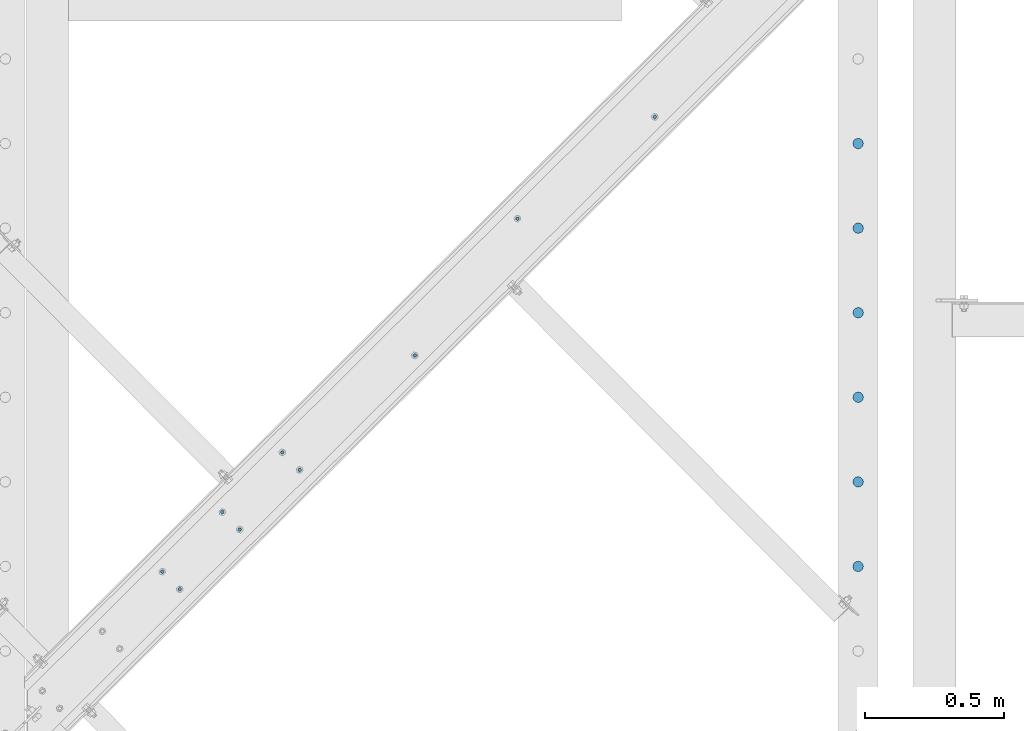
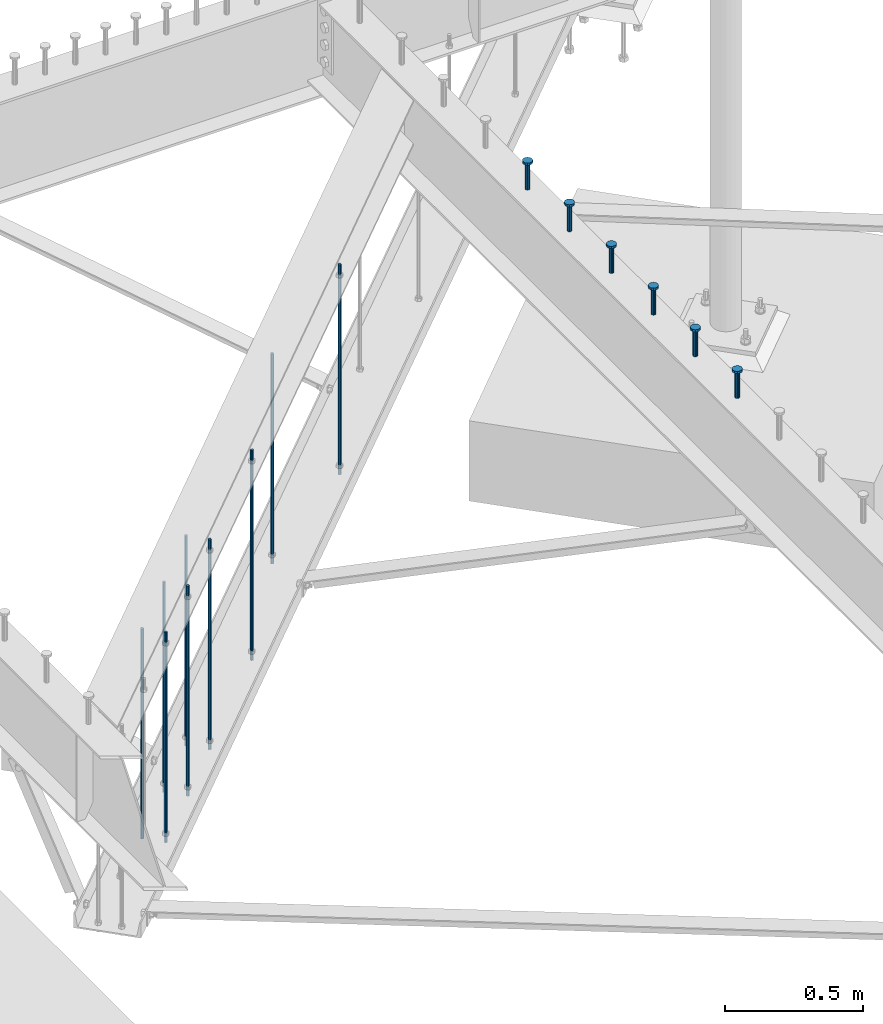
# One storey, part 204 of 975: 15 columns.
"""IFC2X3 building model written with IfcOpenShell, lengths in millimetres."""

from ifc_helpers import new_model, si_unit, frame, origin_with_axes, place, context, subcontext, project, spatial, faceted_brep, material, type_object, element, save


model = new_model("IFC2X3")

# Units and contexts
model_context = context("Model", 3, precision=1e-05, world=origin_with_axes())
body_context = subcontext(model_context, "Body", "Model", "MODEL_VIEW")
ifc_project = project(units=[si_unit("LENGTHUNIT", "METRE", prefix="MILLI"), si_unit("AREAUNIT", "SQUARE_METRE"), si_unit("VOLUMEUNIT", "CUBIC_METRE"), si_unit("MASSUNIT", "GRAM", prefix="KILO"), si_unit("TIMEUNIT", "SECOND"), si_unit("PLANEANGLEUNIT", "RADIAN"), si_unit("SOLIDANGLEUNIT", "STERADIAN"), si_unit("THERMODYNAMICTEMPERATUREUNIT", "DEGREE_CELSIUS"), si_unit("LUMINOUSINTENSITYUNIT", "LUMEN")], contexts=[model_context])

# Site, building, storey
site_placement = place(None, origin_with_axes())
site = spatial("IfcSite", under=ifc_project, at=site_placement, CompositionType="ELEMENT")
building_placement = place(site_placement, origin_with_axes())
building = spatial("IfcBuilding", under=site, at=building_placement, Name="Undefined", CompositionType="ELEMENT")
storey_placement = place(building_placement, origin_with_axes())
storey = spatial("IfcBuildingStorey", under=building, at=storey_placement, Name="Undefined", CompositionType="ELEMENT", Elevation=0.0)

# Columns
ifc_material_1 = material(Name="STEEL/A36")
column_type_1 = type_object("IfcColumnType", PredefinedType="NOTDEFINED")
for number, where, z_axis, x_axis, name in (
    (1, (25047.2443568091, 11120.5428003824, 2870.2), (-0.705007718837806, 0.709199630836842, 0.0), (0.0, 0.0, 1.0), "ALL-THREAD ROD"),
    (2, (25416.8597039642, 11613.4022454247, 2870.2), (-0.705007718837806, 0.709199630836842, 0.0), (0.0, 0.0, 1.0), "ALL-THREAD ROD"),
    (3, (24632.1764227928, 10708.0351225821, 2870.2), (-0.705007718837806, 0.709199630836842, 0.0), (0.0, 0.0, 1.0), "ALL-THREAD ROD"),
    (4, (24416.0123929391, 10493.1487521493, 2870.2), (-0.705007718837806, 0.709199630836842, 0.0), (0.0, 0.0, 1.0), "ALL-THREAD ROD"),
    (5, (24353.3372015628, 10556.1965941899, 2870.2), (-0.705007718837806, 0.709199630836842, 0.0), (0.0, 0.0, 1.0), "ALL-THREAD ROD"),
    (6, (24137.1731717091, 10341.3102237571, 2870.2), (-0.705007718837806, 0.709199630836842, 0.0), (0.0, 0.0, 1.0), "ALL-THREAD ROD"),
    (7, (24199.8483630854, 10278.2623817164, 2870.2), (-0.705007718837806, 0.709199630836842, 0.0), (0.0, 0.0, 1.0), "ALL-THREAD ROD"),
    (8, (25911.9004762635, 11980.0882821533, 2870.2), (-0.705007718837806, 0.709199630836842, 0.0), (0.0, 0.0, 1.0), "ALL-THREAD ROD"),
    (9, (24569.5012314165, 10771.0829646228, 2870.2), (-0.705007718837806, 0.709199630836842, 0.0), (0.0, 0.0, 1.0), "ALL-THREAD ROD"),
):
    element("IfcColumn", number, at=place(storey_placement, frame(where, z_axis=z_axis, x_axis=x_axis)), inside=storey, type_object=column_type_1, material=ifc_material_1, Name=name, context=body_context, shape_type="Brep", body=[
        faceted_brep([(0.0, -6.34999999998763, -3.63797880709171e-12), (0.0, -4.49012806052269, -4.49012806054634), (931.8625, -4.49012806052269, -4.49012806054634), (931.8625, -6.34999999998763, -3.63797880709171e-12), (0.0, 7.27595761418343e-12, -6.35000000000764), (931.8625, 7.27595761418343e-12, -6.35000000000764), (0.0, 4.49012806053724, -4.49012806053906), (931.8625, 4.49012806053724, -4.49012806053906), (0.0, 6.34999999999491, 5.45696821063757e-12), (931.8625, 6.34999999999491, 5.45696821063757e-12), (0.0, 4.49012806052633, 4.49012806054634), (931.8625, 4.49012806052633, 4.49012806054634), (0.0, 0.0, 6.35000000000764), (931.8625, 0.0, 6.35000000000764), (0.0, -4.49012806053361, 4.49012806053543), (931.8625, -4.49012806053361, 4.49012806053543)], [[[0, 1, 2, 3]], [[1, 4, 5, 2]], [[4, 6, 7, 5]], [[6, 8, 9, 7]], [[8, 10, 11, 9]], [[10, 12, 13, 11]], [[12, 14, 15, 13]], [[14, 0, 3, 15]], [[5, 7, 9, 11, 13, 15, 3, 2]], [[14, 12, 10, 8, 6, 4, 1, 0]]]),
    ])
ifc_material_2 = material(Name="STEEL/A108")
column_type_2 = type_object("IfcColumnType", Name="STUD_3/4-DIA", PredefinedType="NOTDEFINED")
column_1_placement = place(storey_placement, frame((26644.6662714101, 11884.025, 3937.0), z_axis=(0.0, 1.0, 0.0), x_axis=(0.0, 0.0, 1.0)))
element("IfcColumn", 10, at=column_1_placement, inside=storey, type_object=column_type_2, material=ifc_material_2, ObjectType="STUD_3/4-DIA", context=body_context, shape_type="Brep", body=[
    faceted_brep([(0.0, -9.52000045776367, 0.0), (0.0, -8.25, -4.76000022888184), (115.57, -8.25, -4.76000022888184), (115.57, -9.52000045776367, 0.0), (0.0, -4.76000022888184, -8.25), (115.57, -4.76000022888184, -8.25), (0.0, 0.0, -9.52000045776367), (115.57, 0.0, -9.52000045776367), (0.0, 4.76000022888184, -8.25), (115.57, 4.76000022888184, -8.25), (0.0, 8.25, -4.76000022888184), (115.57, 8.25, -4.76000022888184), (0.0, 9.52000045776367, 0.0), (115.57, 9.52000045776367, 0.0), (0.0, 8.25, 4.76000022888184), (115.57, 8.25, 4.76000022888184), (0.0, 4.76000022888184, 8.25), (115.57, 4.76000022888184, 8.25), (0.0, 0.0, 9.52000045776367), (115.57, 0.0, 9.52000045776367), (0.0, -4.76000022888184, 8.25), (115.57, -4.76000022888184, 8.25), (0.0, -8.25, 4.76000022888184), (115.57, -8.25, 4.76000022888184), (116.84, -16.5, -9.52000045776367), (116.84, -19.0499992370605, 0.0), (116.84, -9.52000045776367, -16.5), (116.84, 0.0, -19.0499992370605), (116.84, 9.52000045776367, -16.5), (116.84, 16.5, -9.52000045776367), (116.84, 19.0499992370605, 0.0), (116.84, 16.5, 9.52000045776367), (116.84, 9.52000045776367, 16.5), (116.84, 0.0, 19.0499992370605), (116.84, -9.52000045776367, 16.5), (116.84, -16.5, 9.52000045776367), (127.0, -16.5, -9.52000045776367), (127.0, -19.0499992370605, 0.0), (127.0, -9.52000045776367, -16.5), (127.0, 0.0, -19.0499992370605), (127.0, 9.52000045776367, -16.5), (127.0, 16.5, -9.52000045776367), (127.0, 19.0499992370605, 0.0), (127.0, 16.5, 9.52000045776367), (127.0, 9.52000045776367, 16.5), (127.0, 0.0, 19.0499992370605), (127.0, -9.52000045776367, 16.5), (127.0, -16.5, 9.52000045776367)], [[[0, 1, 2, 3]], [[1, 4, 5, 2]], [[4, 6, 7, 5]], [[6, 8, 9, 7]], [[8, 10, 11, 9]], [[10, 12, 13, 11]], [[12, 14, 15, 13]], [[14, 16, 17, 15]], [[16, 18, 19, 17]], [[18, 20, 21, 19]], [[20, 22, 23, 21]], [[22, 0, 3, 23]], [[22, 20, 18, 16, 14, 12, 10, 8, 6, 4, 1, 0]], [[3, 2, 24, 25]], [[2, 5, 26, 24]], [[5, 7, 27, 26]], [[7, 9, 28, 27]], [[9, 11, 29, 28]], [[11, 13, 30, 29]], [[13, 15, 31, 30]], [[15, 17, 32, 31]], [[17, 19, 33, 32]], [[19, 21, 34, 33]], [[21, 23, 35, 34]], [[23, 3, 25, 35]], [[25, 24, 36, 37]], [[24, 26, 38, 36]], [[26, 27, 39, 38]], [[27, 28, 40, 39]], [[28, 29, 41, 40]], [[29, 30, 42, 41]], [[30, 31, 43, 42]], [[31, 32, 44, 43]], [[32, 33, 45, 44]], [[33, 34, 46, 45]], [[34, 35, 47, 46]], [[35, 25, 37, 47]], [[38, 39, 40, 41, 42, 43, 44, 45, 46, 47, 37, 36]]]),
])
column_2_placement = place(storey_placement, frame((26644.6662714101, 11579.225, 3937.0), z_axis=(0.0, 1.0, 0.0), x_axis=(0.0, 0.0, 1.0)))
element("IfcColumn", 11, at=column_2_placement, inside=storey, type_object=column_type_2, material=ifc_material_2, ObjectType="STUD_3/4-DIA", context=body_context, shape_type="Brep", body=[
    faceted_brep([(0.0, -9.52000045776367, 0.0), (0.0, -8.25, -4.76000022888184), (115.57, -8.25, -4.76000022888184), (115.57, -9.52000045776367, 0.0), (0.0, -4.76000022888184, -8.25), (115.57, -4.76000022888184, -8.25), (0.0, 0.0, -9.52000045776367), (115.57, 0.0, -9.52000045776367), (0.0, 4.76000022888184, -8.25), (115.57, 4.76000022888184, -8.25), (0.0, 8.25, -4.76000022888184), (115.57, 8.25, -4.76000022888184), (0.0, 9.52000045776367, 0.0), (115.57, 9.52000045776367, 0.0), (0.0, 8.25, 4.76000022888184), (115.57, 8.25, 4.76000022888184), (0.0, 4.76000022888184, 8.25), (115.57, 4.76000022888184, 8.25), (0.0, 0.0, 9.52000045776367), (115.57, 0.0, 9.52000045776367), (0.0, -4.76000022888184, 8.25), (115.57, -4.76000022888184, 8.25), (0.0, -8.25, 4.76000022888184), (115.57, -8.25, 4.76000022888184), (116.84, -16.5, -9.52000045776367), (116.84, -19.0499992370605, 0.0), (116.84, -9.52000045776367, -16.5), (116.84, 0.0, -19.0499992370605), (116.84, 9.52000045776367, -16.5), (116.84, 16.5, -9.52000045776367), (116.84, 19.0499992370605, 0.0), (116.84, 16.5, 9.52000045776367), (116.84, 9.52000045776367, 16.5), (116.84, 0.0, 19.0499992370605), (116.84, -9.52000045776367, 16.5), (116.84, -16.5, 9.52000045776367), (127.0, -16.5, -9.52000045776367), (127.0, -19.0499992370605, 0.0), (127.0, -9.52000045776367, -16.5), (127.0, 0.0, -19.0499992370605), (127.0, 9.52000045776367, -16.5), (127.0, 16.5, -9.52000045776367), (127.0, 19.0499992370605, 0.0), (127.0, 16.5, 9.52000045776367), (127.0, 9.52000045776367, 16.5), (127.0, 0.0, 19.0499992370605), (127.0, -9.52000045776367, 16.5), (127.0, -16.5, 9.52000045776367)], [[[0, 1, 2, 3]], [[1, 4, 5, 2]], [[4, 6, 7, 5]], [[6, 8, 9, 7]], [[8, 10, 11, 9]], [[10, 12, 13, 11]], [[12, 14, 15, 13]], [[14, 16, 17, 15]], [[16, 18, 19, 17]], [[18, 20, 21, 19]], [[20, 22, 23, 21]], [[22, 0, 3, 23]], [[22, 20, 18, 16, 14, 12, 10, 8, 6, 4, 1, 0]], [[3, 2, 24, 25]], [[2, 5, 26, 24]], [[5, 7, 27, 26]], [[7, 9, 28, 27]], [[9, 11, 29, 28]], [[11, 13, 30, 29]], [[13, 15, 31, 30]], [[15, 17, 32, 31]], [[17, 19, 33, 32]], [[19, 21, 34, 33]], [[21, 23, 35, 34]], [[23, 3, 25, 35]], [[25, 24, 36, 37]], [[24, 26, 38, 36]], [[26, 27, 39, 38]], [[27, 28, 40, 39]], [[28, 29, 41, 40]], [[29, 30, 42, 41]], [[30, 31, 43, 42]], [[31, 32, 44, 43]], [[32, 33, 45, 44]], [[33, 34, 46, 45]], [[34, 35, 47, 46]], [[35, 25, 37, 47]], [[38, 39, 40, 41, 42, 43, 44, 45, 46, 47, 37, 36]]]),
])
column_3_placement = place(storey_placement, frame((26644.6662714101, 11274.425, 3937.0), z_axis=(0.0, 1.0, 0.0), x_axis=(0.0, 0.0, 1.0)))
element("IfcColumn", 12, at=column_3_placement, inside=storey, type_object=column_type_2, material=ifc_material_2, ObjectType="STUD_3/4-DIA", context=body_context, shape_type="Brep", body=[
    faceted_brep([(0.0, -9.52000045776367, 0.0), (0.0, -8.25, -4.76000022888184), (115.57, -8.25, -4.76000022888184), (115.57, -9.52000045776367, 0.0), (0.0, -4.76000022888184, -8.25), (115.57, -4.76000022888184, -8.25), (0.0, 0.0, -9.52000045776367), (115.57, 0.0, -9.52000045776367), (0.0, 4.76000022888184, -8.25), (115.57, 4.76000022888184, -8.25), (0.0, 8.25, -4.76000022888184), (115.57, 8.25, -4.76000022888184), (0.0, 9.52000045776367, 0.0), (115.57, 9.52000045776367, 0.0), (0.0, 8.25, 4.76000022888184), (115.57, 8.25, 4.76000022888184), (0.0, 4.76000022888184, 8.25), (115.57, 4.76000022888184, 8.25), (0.0, 0.0, 9.52000045776367), (115.57, 0.0, 9.52000045776367), (0.0, -4.76000022888184, 8.25), (115.57, -4.76000022888184, 8.25), (0.0, -8.25, 4.76000022888184), (115.57, -8.25, 4.76000022888184), (116.84, -16.5, -9.52000045776367), (116.84, -19.0499992370605, 0.0), (116.84, -9.52000045776367, -16.5), (116.84, 0.0, -19.0499992370605), (116.84, 9.52000045776367, -16.5), (116.84, 16.5, -9.52000045776367), (116.84, 19.0499992370605, 0.0), (116.84, 16.5, 9.52000045776367), (116.84, 9.52000045776367, 16.5), (116.84, 0.0, 19.0499992370605), (116.84, -9.52000045776367, 16.5), (116.84, -16.5, 9.52000045776367), (127.0, -16.5, -9.52000045776367), (127.0, -19.0499992370605, 0.0), (127.0, -9.52000045776367, -16.5), (127.0, 0.0, -19.0499992370605), (127.0, 9.52000045776367, -16.5), (127.0, 16.5, -9.52000045776367), (127.0, 19.0499992370605, 0.0), (127.0, 16.5, 9.52000045776367), (127.0, 9.52000045776367, 16.5), (127.0, 0.0, 19.0499992370605), (127.0, -9.52000045776367, 16.5), (127.0, -16.5, 9.52000045776367)], [[[0, 1, 2, 3]], [[1, 4, 5, 2]], [[4, 6, 7, 5]], [[6, 8, 9, 7]], [[8, 10, 11, 9]], [[10, 12, 13, 11]], [[12, 14, 15, 13]], [[14, 16, 17, 15]], [[16, 18, 19, 17]], [[18, 20, 21, 19]], [[20, 22, 23, 21]], [[22, 0, 3, 23]], [[22, 20, 18, 16, 14, 12, 10, 8, 6, 4, 1, 0]], [[3, 2, 24, 25]], [[2, 5, 26, 24]], [[5, 7, 27, 26]], [[7, 9, 28, 27]], [[9, 11, 29, 28]], [[11, 13, 30, 29]], [[13, 15, 31, 30]], [[15, 17, 32, 31]], [[17, 19, 33, 32]], [[19, 21, 34, 33]], [[21, 23, 35, 34]], [[23, 3, 25, 35]], [[25, 24, 36, 37]], [[24, 26, 38, 36]], [[26, 27, 39, 38]], [[27, 28, 40, 39]], [[28, 29, 41, 40]], [[29, 30, 42, 41]], [[30, 31, 43, 42]], [[31, 32, 44, 43]], [[32, 33, 45, 44]], [[33, 34, 46, 45]], [[34, 35, 47, 46]], [[35, 25, 37, 47]], [[38, 39, 40, 41, 42, 43, 44, 45, 46, 47, 37, 36]]]),
])
column_4_placement = place(storey_placement, frame((26644.6662714101, 10969.625, 3937.0), z_axis=(0.0, 1.0, 0.0), x_axis=(0.0, 0.0, 1.0)))
element("IfcColumn", 13, at=column_4_placement, inside=storey, type_object=column_type_2, material=ifc_material_2, ObjectType="STUD_3/4-DIA", context=body_context, shape_type="Brep", body=[
    faceted_brep([(0.0, -9.52000045776367, 0.0), (0.0, -8.25, -4.76000022888184), (115.57, -8.25, -4.76000022888184), (115.57, -9.52000045776367, 0.0), (0.0, -4.76000022888184, -8.25), (115.57, -4.76000022888184, -8.25), (0.0, 0.0, -9.52000045776367), (115.57, 0.0, -9.52000045776367), (0.0, 4.76000022888184, -8.25), (115.57, 4.76000022888184, -8.25), (0.0, 8.25, -4.76000022888184), (115.57, 8.25, -4.76000022888184), (0.0, 9.52000045776367, 0.0), (115.57, 9.52000045776367, 0.0), (0.0, 8.25, 4.76000022888184), (115.57, 8.25, 4.76000022888184), (0.0, 4.76000022888184, 8.25), (115.57, 4.76000022888184, 8.25), (0.0, 0.0, 9.52000045776367), (115.57, 0.0, 9.52000045776367), (0.0, -4.76000022888184, 8.25), (115.57, -4.76000022888184, 8.25), (0.0, -8.25, 4.76000022888184), (115.57, -8.25, 4.76000022888184), (116.84, -16.5, -9.52000045776367), (116.84, -19.0499992370605, 0.0), (116.84, -9.52000045776367, -16.5), (116.84, 0.0, -19.0499992370605), (116.84, 9.52000045776367, -16.5), (116.84, 16.5, -9.52000045776367), (116.84, 19.0499992370605, 0.0), (116.84, 16.5, 9.52000045776367), (116.84, 9.52000045776367, 16.5), (116.84, 0.0, 19.0499992370605), (116.84, -9.52000045776367, 16.5), (116.84, -16.5, 9.52000045776367), (127.0, -16.5, -9.52000045776367), (127.0, -19.0499992370605, 0.0), (127.0, -9.52000045776367, -16.5), (127.0, 0.0, -19.0499992370605), (127.0, 9.52000045776367, -16.5), (127.0, 16.5, -9.52000045776367), (127.0, 19.0499992370605, 0.0), (127.0, 16.5, 9.52000045776367), (127.0, 9.52000045776367, 16.5), (127.0, 0.0, 19.0499992370605), (127.0, -9.52000045776367, 16.5), (127.0, -16.5, 9.52000045776367)], [[[0, 1, 2, 3]], [[1, 4, 5, 2]], [[4, 6, 7, 5]], [[6, 8, 9, 7]], [[8, 10, 11, 9]], [[10, 12, 13, 11]], [[12, 14, 15, 13]], [[14, 16, 17, 15]], [[16, 18, 19, 17]], [[18, 20, 21, 19]], [[20, 22, 23, 21]], [[22, 0, 3, 23]], [[22, 20, 18, 16, 14, 12, 10, 8, 6, 4, 1, 0]], [[3, 2, 24, 25]], [[2, 5, 26, 24]], [[5, 7, 27, 26]], [[7, 9, 28, 27]], [[9, 11, 29, 28]], [[11, 13, 30, 29]], [[13, 15, 31, 30]], [[15, 17, 32, 31]], [[17, 19, 33, 32]], [[19, 21, 34, 33]], [[21, 23, 35, 34]], [[23, 3, 25, 35]], [[25, 24, 36, 37]], [[24, 26, 38, 36]], [[26, 27, 39, 38]], [[27, 28, 40, 39]], [[28, 29, 41, 40]], [[29, 30, 42, 41]], [[30, 31, 43, 42]], [[31, 32, 44, 43]], [[32, 33, 45, 44]], [[33, 34, 46, 45]], [[34, 35, 47, 46]], [[35, 25, 37, 47]], [[38, 39, 40, 41, 42, 43, 44, 45, 46, 47, 37, 36]]]),
])
column_5_placement = place(storey_placement, frame((26644.6662714101, 10664.825, 3937.0), z_axis=(0.0, 1.0, 0.0), x_axis=(0.0, 0.0, 1.0)))
element("IfcColumn", 14, at=column_5_placement, inside=storey, type_object=column_type_2, material=ifc_material_2, ObjectType="STUD_3/4-DIA", context=body_context, shape_type="Brep", body=[
    faceted_brep([(0.0, -9.52000045776367, 0.0), (0.0, -8.25, -4.76000022888184), (115.57, -8.25, -4.76000022888184), (115.57, -9.52000045776367, 0.0), (0.0, -4.76000022888184, -8.25), (115.57, -4.76000022888184, -8.25), (0.0, 0.0, -9.52000045776367), (115.57, 0.0, -9.52000045776367), (0.0, 4.76000022888184, -8.25), (115.57, 4.76000022888184, -8.25), (0.0, 8.25, -4.76000022888184), (115.57, 8.25, -4.76000022888184), (0.0, 9.52000045776367, 0.0), (115.57, 9.52000045776367, 0.0), (0.0, 8.25, 4.76000022888184), (115.57, 8.25, 4.76000022888184), (0.0, 4.76000022888184, 8.25), (115.57, 4.76000022888184, 8.25), (0.0, 0.0, 9.52000045776367), (115.57, 0.0, 9.52000045776367), (0.0, -4.76000022888184, 8.25), (115.57, -4.76000022888184, 8.25), (0.0, -8.25, 4.76000022888184), (115.57, -8.25, 4.76000022888184), (116.84, -16.5, -9.52000045776367), (116.84, -19.0499992370605, 0.0), (116.84, -9.52000045776367, -16.5), (116.84, 0.0, -19.0499992370605), (116.84, 9.52000045776367, -16.5), (116.84, 16.5, -9.52000045776367), (116.84, 19.0499992370605, 0.0), (116.84, 16.5, 9.52000045776367), (116.84, 9.52000045776367, 16.5), (116.84, 0.0, 19.0499992370605), (116.84, -9.52000045776367, 16.5), (116.84, -16.5, 9.52000045776367), (127.0, -16.5, -9.52000045776367), (127.0, -19.0499992370605, 0.0), (127.0, -9.52000045776367, -16.5), (127.0, 0.0, -19.0499992370605), (127.0, 9.52000045776367, -16.5), (127.0, 16.5, -9.52000045776367), (127.0, 19.0499992370605, 0.0), (127.0, 16.5, 9.52000045776367), (127.0, 9.52000045776367, 16.5), (127.0, 0.0, 19.0499992370605), (127.0, -9.52000045776367, 16.5), (127.0, -16.5, 9.52000045776367)], [[[0, 1, 2, 3]], [[1, 4, 5, 2]], [[4, 6, 7, 5]], [[6, 8, 9, 7]], [[8, 10, 11, 9]], [[10, 12, 13, 11]], [[12, 14, 15, 13]], [[14, 16, 17, 15]], [[16, 18, 19, 17]], [[18, 20, 21, 19]], [[20, 22, 23, 21]], [[22, 0, 3, 23]], [[22, 20, 18, 16, 14, 12, 10, 8, 6, 4, 1, 0]], [[3, 2, 24, 25]], [[2, 5, 26, 24]], [[5, 7, 27, 26]], [[7, 9, 28, 27]], [[9, 11, 29, 28]], [[11, 13, 30, 29]], [[13, 15, 31, 30]], [[15, 17, 32, 31]], [[17, 19, 33, 32]], [[19, 21, 34, 33]], [[21, 23, 35, 34]], [[23, 3, 25, 35]], [[25, 24, 36, 37]], [[24, 26, 38, 36]], [[26, 27, 39, 38]], [[27, 28, 40, 39]], [[28, 29, 41, 40]], [[29, 30, 42, 41]], [[30, 31, 43, 42]], [[31, 32, 44, 43]], [[32, 33, 45, 44]], [[33, 34, 46, 45]], [[34, 35, 47, 46]], [[35, 25, 37, 47]], [[38, 39, 40, 41, 42, 43, 44, 45, 46, 47, 37, 36]]]),
])
column_6_placement = place(storey_placement, frame((26644.6662714101, 10360.025, 3937.0), z_axis=(0.0, 1.0, 0.0), x_axis=(0.0, 0.0, 1.0)))
element("IfcColumn", 15, at=column_6_placement, inside=storey, type_object=column_type_2, material=ifc_material_2, ObjectType="STUD_3/4-DIA", context=body_context, shape_type="Brep", body=[
    faceted_brep([(0.0, -9.52000045776367, 0.0), (0.0, -8.25, -4.76000022888184), (115.57, -8.25, -4.76000022888184), (115.57, -9.52000045776367, 0.0), (0.0, -4.76000022888184, -8.25), (115.57, -4.76000022888184, -8.25), (0.0, 0.0, -9.52000045776367), (115.57, 0.0, -9.52000045776367), (0.0, 4.76000022888184, -8.25), (115.57, 4.76000022888184, -8.25), (0.0, 8.25, -4.76000022888184), (115.57, 8.25, -4.76000022888184), (0.0, 9.52000045776367, 0.0), (115.57, 9.52000045776367, 0.0), (0.0, 8.25, 4.76000022888184), (115.57, 8.25, 4.76000022888184), (0.0, 4.76000022888184, 8.25), (115.57, 4.76000022888184, 8.25), (0.0, 0.0, 9.52000045776367), (115.57, 0.0, 9.52000045776367), (0.0, -4.76000022888184, 8.25), (115.57, -4.76000022888184, 8.25), (0.0, -8.25, 4.76000022888184), (115.57, -8.25, 4.76000022888184), (116.84, -16.5, -9.52000045776367), (116.84, -19.0499992370605, 0.0), (116.84, -9.52000045776367, -16.5), (116.84, 0.0, -19.0499992370605), (116.84, 9.52000045776367, -16.5), (116.84, 16.5, -9.52000045776367), (116.84, 19.0499992370605, 0.0), (116.84, 16.5, 9.52000045776367), (116.84, 9.52000045776367, 16.5), (116.84, 0.0, 19.0499992370605), (116.84, -9.52000045776367, 16.5), (116.84, -16.5, 9.52000045776367), (127.0, -16.5, -9.52000045776367), (127.0, -19.0499992370605, 0.0), (127.0, -9.52000045776367, -16.5), (127.0, 0.0, -19.0499992370605), (127.0, 9.52000045776367, -16.5), (127.0, 16.5, -9.52000045776367), (127.0, 19.0499992370605, 0.0), (127.0, 16.5, 9.52000045776367), (127.0, 9.52000045776367, 16.5), (127.0, 0.0, 19.0499992370605), (127.0, -9.52000045776367, 16.5), (127.0, -16.5, 9.52000045776367)], [[[0, 1, 2, 3]], [[1, 4, 5, 2]], [[4, 6, 7, 5]], [[6, 8, 9, 7]], [[8, 10, 11, 9]], [[10, 12, 13, 11]], [[12, 14, 15, 13]], [[14, 16, 17, 15]], [[16, 18, 19, 17]], [[18, 20, 21, 19]], [[20, 22, 23, 21]], [[22, 0, 3, 23]], [[22, 20, 18, 16, 14, 12, 10, 8, 6, 4, 1, 0]], [[3, 2, 24, 25]], [[2, 5, 26, 24]], [[5, 7, 27, 26]], [[7, 9, 28, 27]], [[9, 11, 29, 28]], [[11, 13, 30, 29]], [[13, 15, 31, 30]], [[15, 17, 32, 31]], [[17, 19, 33, 32]], [[19, 21, 34, 33]], [[21, 23, 35, 34]], [[23, 3, 25, 35]], [[25, 24, 36, 37]], [[24, 26, 38, 36]], [[26, 27, 39, 38]], [[27, 28, 40, 39]], [[28, 29, 41, 40]], [[29, 30, 42, 41]], [[30, 31, 43, 42]], [[31, 32, 44, 43]], [[32, 33, 45, 44]], [[33, 34, 46, 45]], [[34, 35, 47, 46]], [[35, 25, 37, 47]], [[38, 39, 40, 41, 42, 43, 44, 45, 46, 47, 37, 36]]]),
])

save(model, "model.ifc")
